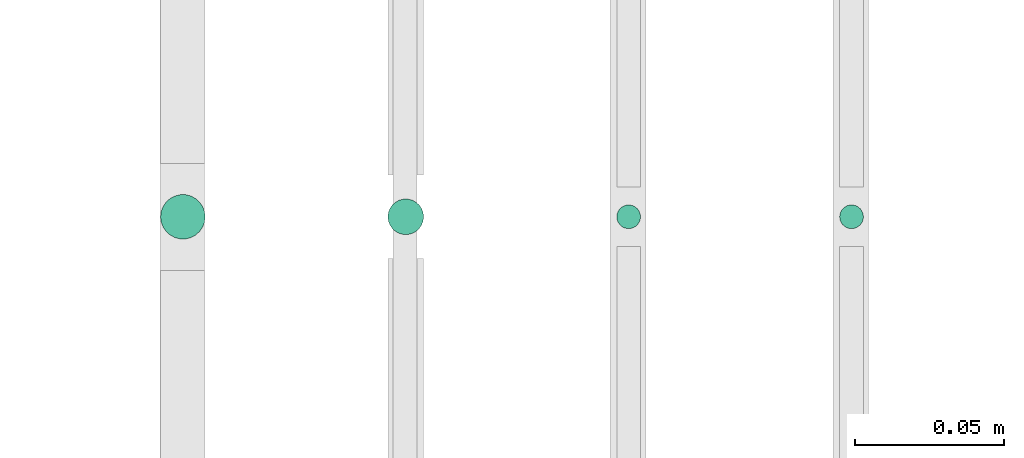
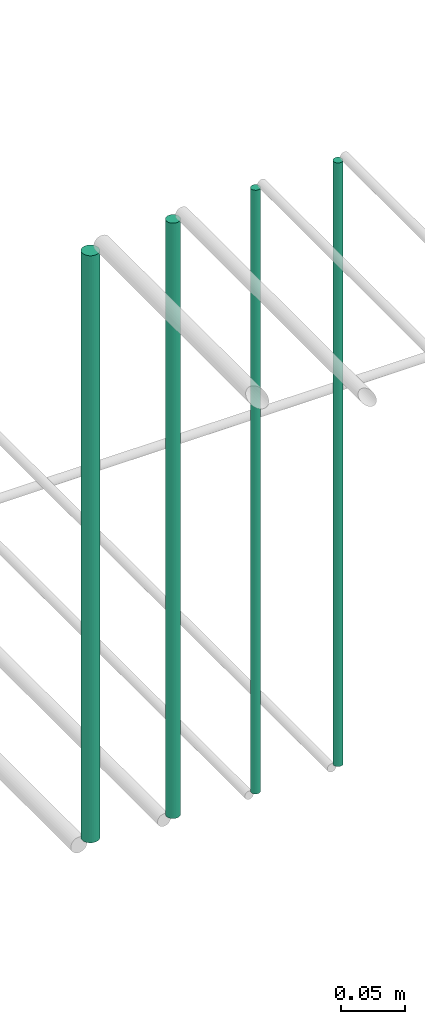
# One storey, part 124 of 331: 4 flow segments.
"""IFC2X3 building model written with IfcOpenShell, lengths in millimetres."""

from ifc_helpers import new_model, entity, si_unit, converted_unit, derived_unit, direction, frame, frame_2d, origin, origin_2d_with_axis, place, context, subcontext, project, spatial, circle, extrude, type_object, element, save


model = new_model("IFC2X3")

# Units and contexts
model_context = context("Model", 3, precision=0.01, world=origin(), true_north=direction((6.12303176911189e-17, 1.0)))
body_context = subcontext(model_context, "Body", "Model", "MODEL_VIEW")
ifc_project = project(units=[si_unit("LENGTHUNIT", "METRE", prefix="MILLI"), si_unit("AREAUNIT", "SQUARE_METRE"), si_unit("VOLUMEUNIT", "CUBIC_METRE"), converted_unit("PLANEANGLEUNIT", "DEGREE", entity("IfcRatioMeasure", 0.0174532925199433), si_unit("PLANEANGLEUNIT", "RADIAN"), dimensions=[0, 0, 0, 0, 0, 0, 0]), si_unit("MASSUNIT", "GRAM", prefix="KILO"), derived_unit("MASSDENSITYUNIT", [(si_unit("MASSUNIT", "GRAM", prefix="KILO"), 1), (si_unit("LENGTHUNIT", "METRE"), -3)]), derived_unit("MOMENTOFINERTIAUNIT", [(si_unit("LENGTHUNIT", "METRE"), 4)]), si_unit("TIMEUNIT", "SECOND"), si_unit("FREQUENCYUNIT", "HERTZ"), si_unit("THERMODYNAMICTEMPERATUREUNIT", "DEGREE_CELSIUS"), derived_unit("THERMALTRANSMITTANCEUNIT", [(si_unit("MASSUNIT", "GRAM", prefix="KILO"), 1), (si_unit("THERMODYNAMICTEMPERATUREUNIT", "KELVIN"), -1), (si_unit("TIMEUNIT", "SECOND"), -3)]), derived_unit("VOLUMETRICFLOWRATEUNIT", [(si_unit("LENGTHUNIT", "METRE"), 3), (si_unit("TIMEUNIT", "SECOND"), -1)]), derived_unit("MASSFLOWRATEUNIT", [(si_unit("MASSUNIT", "GRAM", prefix="KILO"), 1), (si_unit("TIMEUNIT", "SECOND"), -1)]), derived_unit("ROTATIONALFREQUENCYUNIT", [(si_unit("TIMEUNIT", "SECOND"), -1)]), si_unit("ELECTRICCURRENTUNIT", "AMPERE"), si_unit("ELECTRICVOLTAGEUNIT", "VOLT"), si_unit("POWERUNIT", "WATT"), si_unit("FORCEUNIT", "NEWTON", prefix="KILO"), si_unit("ILLUMINANCEUNIT", "LUX"), si_unit("LUMINOUSFLUXUNIT", "LUMEN"), si_unit("LUMINOUSINTENSITYUNIT", "CANDELA"), derived_unit("USERDEFINED", [(si_unit("MASSUNIT", "GRAM", prefix="KILO"), -1), (si_unit("LENGTHUNIT", "METRE"), -2), (si_unit("TIMEUNIT", "SECOND"), 3), (si_unit("LUMINOUSFLUXUNIT", "LUMEN"), 1)]), derived_unit("LINEARVELOCITYUNIT", [(si_unit("LENGTHUNIT", "METRE"), 1), (si_unit("TIMEUNIT", "SECOND"), -1)]), si_unit("PRESSUREUNIT", "PASCAL"), derived_unit("USERDEFINED", [(si_unit("LENGTHUNIT", "METRE"), -2), (si_unit("MASSUNIT", "GRAM", prefix="KILO"), 1), (si_unit("TIMEUNIT", "SECOND"), -2)]), derived_unit("LINEARFORCEUNIT", [(si_unit("MASSUNIT", "GRAM", prefix="KILO"), 1), (si_unit("LENGTHUNIT", "METRE"), 1), (si_unit("TIMEUNIT", "SECOND"), -2), (si_unit("LENGTHUNIT", "METRE"), -1)]), derived_unit("PLANARFORCEUNIT", [(si_unit("MASSUNIT", "GRAM", prefix="KILO"), 1), (si_unit("LENGTHUNIT", "METRE"), 1), (si_unit("TIMEUNIT", "SECOND"), -2), (si_unit("LENGTHUNIT", "METRE"), -2)])], contexts=[model_context])

# Site, building, storey
site_placement = place(None, frame((0.0, -0.00077364408347762, 0.0)))
site = spatial("IfcSite", under=ifc_project, at=site_placement, CompositionType="ELEMENT")
building_placement = place(site_placement, origin())
building = spatial("IfcBuilding", under=site, at=building_placement, CompositionType="ELEMENT")
storey_placement = place(building_placement, origin())
storey = spatial("IfcBuildingStorey", under=building, at=storey_placement, CompositionType="ELEMENT", Elevation=0.0)

# Flow segments
pipe_segment_type = type_object("IfcPipeSegmentType", PredefinedType="NOTDEFINED")
flow_segment_1_placement = place(storey_placement, frame((20840.733655358, 5638.02529159145, 18460.0)))
element("IfcFlowSegment", 1, at=flow_segment_1_placement, inside=storey, type_object=pipe_segment_type, context=body_context, shape_type="SweptSolid", body=[
    extrude(circle(Radius=4.0, at=origin_2d_with_axis()), frame((5.59527223591499, 5.59527223591607, 0.0), z_axis=(0.0, 0.0, 1.0), x_axis=(-1.0, 0.0, 0.0)), (0.0, 0.0, 1.0), 580.000000000015),
])
flow_segment_2_placement = place(storey_placement, frame((20765.733655358, 5638.02529159145, 18460.0)))
element("IfcFlowSegment", 2, at=flow_segment_2_placement, inside=storey, type_object=pipe_segment_type, context=body_context, shape_type="SweptSolid", body=[
    extrude(circle(Radius=4.0, at=frame_2d((0.0, -1.08286712929839e-12), x_axis=(1.0, 0.0))), frame((5.59527223591499, 5.59527223591499, 0.0), z_axis=(0.0, 0.0, 1.0), x_axis=(-1.0, 0.0, 0.0)), (0.0, 0.0, 1.0), 580.0),
])
flow_segment_3_placement = place(storey_placement, frame((20688.733655358, 5636.02529159146, 18464.0)))
element("IfcFlowSegment", 3, at=flow_segment_3_placement, inside=storey, type_object=pipe_segment_type, context=body_context, shape_type="SweptSolid", body=[
    extrude(circle(Radius=6.0, at=origin_2d_with_axis()), frame((7.59527223591454, 7.59527223591562, 0.0), z_axis=(0.0, 0.0, 1.0), x_axis=(-1.0, 0.0, 0.0)), (0.0, 0.0, 1.0), 572.000000000011),
])
flow_segment_4_placement = place(storey_placement, frame((20612.233655358, 5634.52529159146, 18468.0)))
element("IfcFlowSegment", 4, at=flow_segment_4_placement, inside=storey, type_object=pipe_segment_type, context=body_context, shape_type="SweptSolid", body=[
    extrude(circle(Radius=7.5, at=origin_2d_with_axis()), frame((9.09527223591419, 9.09527223591636, 0.0), z_axis=(0.0, 0.0, 1.0), x_axis=(-1.0, 0.0, 0.0)), (0.0, 0.0, 1.0), 564.00000000001),
])

save(model, "model.ifc")
